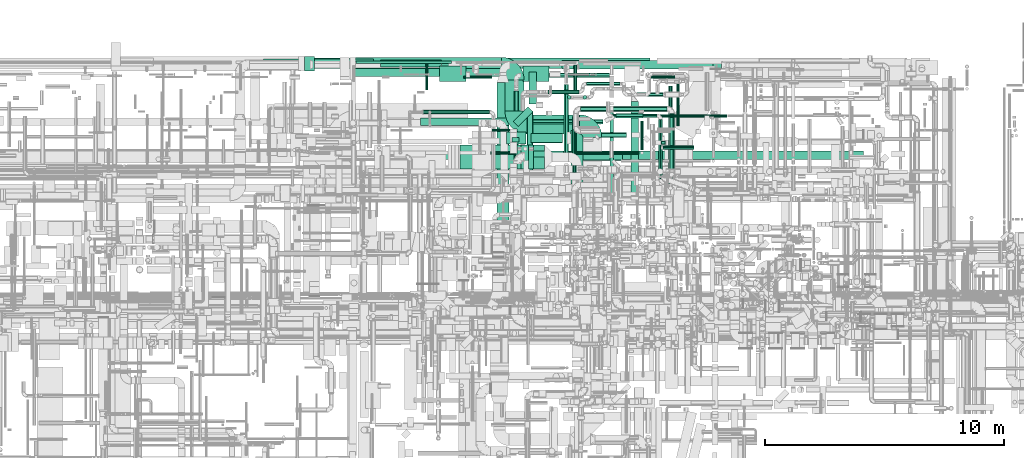
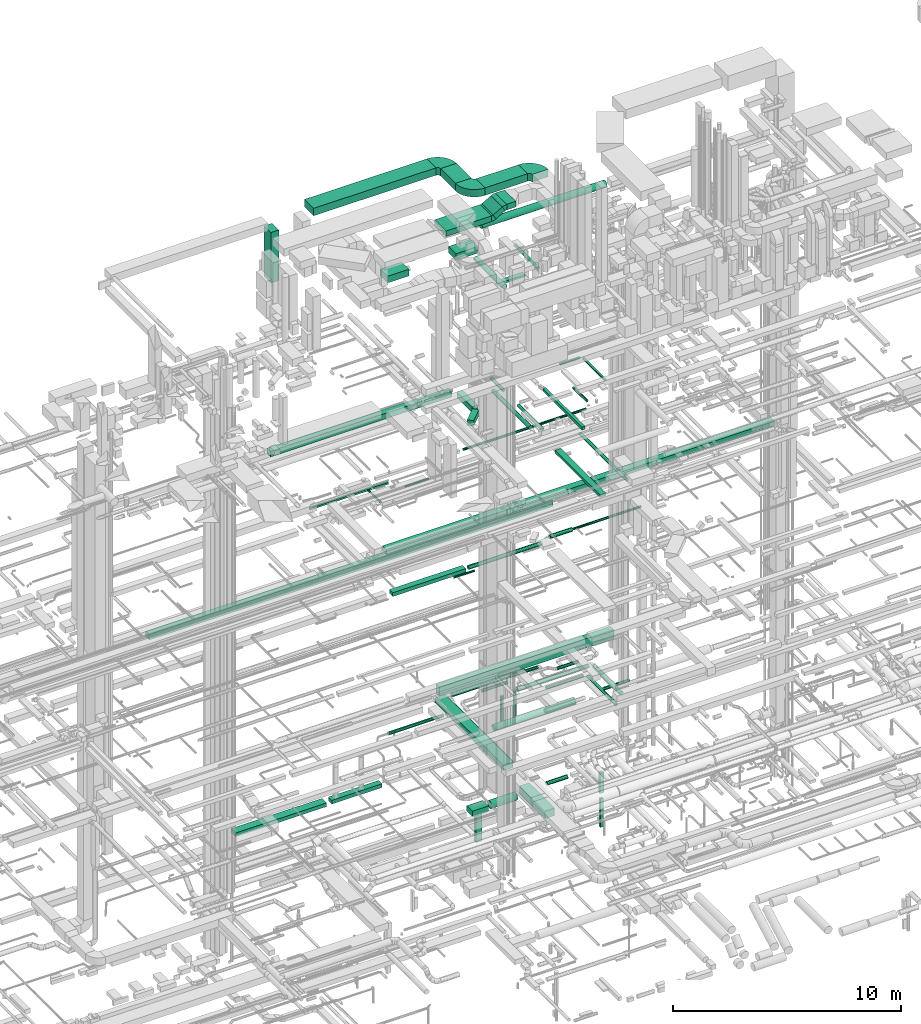
# One storey, part 74 of 337: 61 flow segments, 5 flow fittings.
"""IFC2X3 building model written with IfcOpenShell, lengths in millimetres."""

from ifc_helpers import new_model, entity, si_unit, converted_unit, derived_unit, direction, frame, frame_2d, origin, origin_2d_with_axis, place, context, subcontext, project, spatial, polyline, circle_curve, parameter, trimmed, segment, composite_curve, rectangle, circle, outline, extrude, source, transform, mapped, material, type_object, type_shapes, element, save


model = new_model("IFC2X3")

# Units and contexts
model_context = context("Model", 3, precision=0.01, world=origin(), true_north=direction((6.12303176911189e-17, 1.0)))
body_context = subcontext(model_context, "Body", "Model", "MODEL_VIEW")
ifc_project = project(units=[si_unit("LENGTHUNIT", "METRE", prefix="MILLI"), si_unit("AREAUNIT", "SQUARE_METRE"), si_unit("VOLUMEUNIT", "CUBIC_METRE"), converted_unit("PLANEANGLEUNIT", "DEGREE", entity("IfcRatioMeasure", 0.0174532925199433), si_unit("PLANEANGLEUNIT", "RADIAN"), dimensions=[0, 0, 0, 0, 0, 0, 0]), si_unit("MASSUNIT", "GRAM", prefix="KILO"), derived_unit("MASSDENSITYUNIT", [(si_unit("MASSUNIT", "GRAM", prefix="KILO"), 1), (si_unit("LENGTHUNIT", "METRE"), -3)]), derived_unit("MOMENTOFINERTIAUNIT", [(si_unit("LENGTHUNIT", "METRE"), 4)]), si_unit("TIMEUNIT", "SECOND"), si_unit("FREQUENCYUNIT", "HERTZ"), si_unit("THERMODYNAMICTEMPERATUREUNIT", "DEGREE_CELSIUS"), derived_unit("THERMALTRANSMITTANCEUNIT", [(si_unit("MASSUNIT", "GRAM", prefix="KILO"), 1), (si_unit("THERMODYNAMICTEMPERATUREUNIT", "KELVIN"), -1), (si_unit("TIMEUNIT", "SECOND"), -3)]), derived_unit("VOLUMETRICFLOWRATEUNIT", [(si_unit("LENGTHUNIT", "METRE"), 3), (si_unit("TIMEUNIT", "SECOND"), -1)]), derived_unit("MASSFLOWRATEUNIT", [(si_unit("MASSUNIT", "GRAM", prefix="KILO"), 1), (si_unit("TIMEUNIT", "SECOND"), -1)]), derived_unit("ROTATIONALFREQUENCYUNIT", [(si_unit("TIMEUNIT", "SECOND"), -1)]), si_unit("ELECTRICCURRENTUNIT", "AMPERE"), si_unit("ELECTRICVOLTAGEUNIT", "VOLT"), si_unit("POWERUNIT", "WATT"), si_unit("FORCEUNIT", "NEWTON", prefix="KILO"), si_unit("ILLUMINANCEUNIT", "LUX"), si_unit("LUMINOUSFLUXUNIT", "LUMEN"), si_unit("LUMINOUSINTENSITYUNIT", "CANDELA"), derived_unit("USERDEFINED", [(si_unit("MASSUNIT", "GRAM", prefix="KILO"), -1), (si_unit("LENGTHUNIT", "METRE"), -2), (si_unit("TIMEUNIT", "SECOND"), 3), (si_unit("LUMINOUSFLUXUNIT", "LUMEN"), 1)]), derived_unit("LINEARVELOCITYUNIT", [(si_unit("LENGTHUNIT", "METRE"), 1), (si_unit("TIMEUNIT", "SECOND"), -1)]), si_unit("PRESSUREUNIT", "PASCAL"), derived_unit("USERDEFINED", [(si_unit("LENGTHUNIT", "METRE"), -2), (si_unit("MASSUNIT", "GRAM", prefix="KILO"), 1), (si_unit("TIMEUNIT", "SECOND"), -2)]), derived_unit("LINEARFORCEUNIT", [(si_unit("MASSUNIT", "GRAM", prefix="KILO"), 1), (si_unit("LENGTHUNIT", "METRE"), 1), (si_unit("TIMEUNIT", "SECOND"), -2), (si_unit("LENGTHUNIT", "METRE"), -1)]), derived_unit("PLANARFORCEUNIT", [(si_unit("MASSUNIT", "GRAM", prefix="KILO"), 1), (si_unit("LENGTHUNIT", "METRE"), 1), (si_unit("TIMEUNIT", "SECOND"), -2), (si_unit("LENGTHUNIT", "METRE"), -2)])], contexts=[model_context])

# Site, building, storey
site_placement = place(None, origin())
site = spatial("IfcSite", under=ifc_project, at=site_placement, CompositionType="ELEMENT")
building_placement = place(site_placement, origin())
building = spatial("IfcBuilding", under=site, at=building_placement, CompositionType="ELEMENT")
storey_placement = place(building_placement, origin())
storey = spatial("IfcBuildingStorey", under=building, at=storey_placement, CompositionType="ELEMENT", Elevation=0.0)

# Flow segments
duct_segment_type_1 = type_object("IfcDuctSegmentType", PredefinedType="NOTDEFINED")
flow_segment_1_placement = place(storey_placement, frame((36314.51, 19663.8, -700.0)))
element("IfcFlowSegment", 1, at=flow_segment_1_placement, inside=storey, type_object=duct_segment_type_1, context=body_context, shape_type="SweptSolid", body=[
    extrude(rectangle(XDim=4599.07089300011, YDim=400.0, at=origin_2d_with_axis()), frame((2299.54, 200.0, 0.0)), (0.0, 0.0, 1.0), 200.0),
])
flow_segment_2_placement = place(storey_placement, frame((41213.58, 19713.8, -700.0)))
element("IfcFlowSegment", 2, at=flow_segment_2_placement, inside=storey, type_object=duct_segment_type_1, context=body_context, shape_type="SweptSolid", body=[
    extrude(rectangle(XDim=2541.39164700007, YDim=300.000000000001, at=origin_2d_with_axis()), frame((1270.7, 150.0, 0.0)), (0.0, 0.0, 1.0), 200.0),
])
flow_segment_3_placement = place(storey_placement, frame((49169.33, 14818.39, -1300.0)))
element("IfcFlowSegment", 3, at=flow_segment_3_placement, inside=storey, type_object=duct_segment_type_1, context=body_context, shape_type="SweptSolid", body=[
    extrude(rectangle(XDim=2239.99999999998, YDim=499.999999999999, at=origin_2d_with_axis()), frame((250.0, 1120.0, 0.0), z_axis=(0.0, 0.0, 1.0), x_axis=(0.0, 1.0, 0.0)), (0.0, 0.0, 1.0), 400.0),
])
flow_segment_4_placement = place(storey_placement, frame((52926.91, 16473.87, -2275.0)))
element("IfcFlowSegment", 4, at=flow_segment_4_placement, inside=storey, type_object=duct_segment_type_1, context=body_context, shape_type="SweptSolid", body=[
    extrude(rectangle(XDim=150.000000000001, YDim=199.999999999998, at=origin_2d_with_axis()), frame((100.0, 75.0, 0.0), z_axis=(0.0, 0.0, 1.0), x_axis=(0.0, 1.0, 0.0)), (0.0, 0.0, 1.0), 1079.99998577772),
])
flow_segment_5_placement = place(storey_placement, frame((52951.91, 16498.87, -4115.0)))
element("IfcFlowSegment", 5, at=flow_segment_5_placement, inside=storey, type_object=duct_segment_type_1, context=body_context, shape_type="SweptSolid", body=[
    extrude(rectangle(XDim=99.9999999999989, YDim=150.000000000001, at=origin_2d_with_axis()), frame((75.0, 50.0, 0.0), z_axis=(0.0, 0.0, 1.0), x_axis=(0.0, 1.0, 0.0)), (0.0, 0.0, 1.0), 1540.00000000006),
])
flow_segment_6_placement = place(storey_placement, frame((46476.19, 16499.25, -1275.0)))
element("IfcFlowSegment", 6, at=flow_segment_6_placement, inside=storey, type_object=duct_segment_type_1, context=body_context, shape_type="SweptSolid", body=[
    extrude(rectangle(XDim=816.497543824669, YDim=500.000000000001, at=origin_2d_with_axis()), frame((408.25, 250.0, 0.0), z_axis=(0.0, 0.0, 1.0), x_axis=(-1.0, 0.0, 0.0)), (0.0, 0.0, 1.0), 300.0),
])
flow_segment_7_placement = place(storey_placement, frame((46701.91, 16574.25, -2790.0)))
element("IfcFlowSegment", 7, at=flow_segment_7_placement, inside=storey, type_object=duct_segment_type_1, context=body_context, shape_type="SweptSolid", body=[
    extrude(rectangle(XDim=300.000000000001, YDim=200.0, at=origin_2d_with_axis()), frame((150.0, 100.0, 0.0)), (0.0, 0.0, 1.0), 1495.00000000003),
])
flow_segment_8_placement = place(storey_placement, frame((32013.84, 19801.06, 11250.0)))
element("IfcFlowSegment", 8, at=flow_segment_8_placement, inside=storey, type_object=duct_segment_type_1, context=body_context, shape_type="SweptSolid", body=[
    extrude(rectangle(XDim=20460.0, YDim=300.000000000001, at=origin_2d_with_axis()), frame((10230.0, 150.0, 0.0), z_axis=(0.0, 0.0, 1.0), x_axis=(-1.0, 0.0, 0.0)), (0.0, 0.0, 1.0), 300.000000000001),
])
flow_segment_9_placement = place(storey_placement, frame((42886.82, 17278.1, 11300.0)))
element("IfcFlowSegment", 9, at=flow_segment_9_placement, inside=storey, type_object=duct_segment_type_1, context=body_context, shape_type="SweptSolid", body=[
    extrude(rectangle(XDim=3700.48000586036, YDim=299.999999999999, at=origin_2d_with_axis()), frame((1850.24, 150.0, 0.0)), (0.0, 0.0, 1.0), 199.999999999998),
])
flow_segment_10_placement = place(storey_placement, frame((46625.84, 19646.24, 3200.0)))
element("IfcFlowSegment", 10, at=flow_segment_10_placement, inside=storey, type_object=duct_segment_type_1, context=body_context, shape_type="SweptSolid", body=[
    extrude(rectangle(XDim=8830.00000000004, YDim=300.000000000001, at=origin_2d_with_axis()), frame((4415.0, 150.0, 0.0), z_axis=(0.0, 0.0, 1.0), x_axis=(-1.0, 0.0, 0.0)), (0.0, 0.0, 1.0), 500.0),
])
flow_segment_11_placement = place(storey_placement, frame((38062.78, 19650.32, 19020.0)))
element("IfcFlowSegment", 11, at=flow_segment_11_placement, inside=storey, type_object=duct_segment_type_1, context=body_context, shape_type="SweptSolid", body=[
    extrude(rectangle(XDim=9206.25000000004, YDim=300.000000000001, at=origin_2d_with_axis()), frame((4603.13, 150.0, 0.0)), (0.0, 0.0, 1.0), 300.000000000001),
])
flow_segment_12_placement = place(storey_placement, frame((41748.68, 15850.0, 14825.0)))
element("IfcFlowSegment", 12, at=flow_segment_12_placement, inside=storey, type_object=duct_segment_type_1, context=body_context, shape_type="SweptSolid", body=[
    extrude(rectangle(XDim=19645.3394213711, YDim=350.000000000001, at=origin_2d_with_axis()), frame((9822.67, 175.0, 0.0)), (0.0, 0.0, 1.0), 249.999999999999),
])
flow_segment_13_placement = place(storey_placement, frame((50799.92, 14382.73, 19200.0)))
element("IfcFlowSegment", 13, at=flow_segment_13_placement, inside=storey, type_object=duct_segment_type_1, context=body_context, shape_type="SweptSolid", body=[
    extrude(rectangle(XDim=3427.07429120735, YDim=150.000000000001, at=origin_2d_with_axis()), frame((75.0, 1713.54, 0.0), z_axis=(0.0, 0.0, 1.0), x_axis=(0.0, -1.0, 0.0)), (0.0, 0.0, 1.0), 150.000000000001),
])
flow_segment_14_placement = place(storey_placement, frame((40192.01, 19863.88, 15300.0)))
element("IfcFlowSegment", 14, at=flow_segment_14_placement, inside=storey, type_object=duct_segment_type_1, context=body_context, shape_type="SweptSolid", body=[
    extrude(rectangle(XDim=3980.0, YDim=99.9999999999989, at=origin_2d_with_axis()), frame((1990.0, 50.0, 0.0)), (0.0, 0.0, 1.0), 99.9999999999989),
])
flow_segment_15_placement = place(storey_placement, frame((47419.03, 18167.72, 19020.0)))
element("IfcFlowSegment", 15, at=flow_segment_15_placement, inside=storey, type_object=duct_segment_type_1, context=body_context, shape_type="SweptSolid", body=[
    extrude(rectangle(XDim=1332.59991693868, YDim=300.000000000001, at=origin_2d_with_axis()), frame((150.0, 666.3, 0.0), z_axis=(0.0, 0.0, 1.0), x_axis=(0.0, -1.0, 0.0)), (0.0, 0.0, 1.0), 300.000000000001),
])
flow_segment_16_placement = place(storey_placement, frame((46750.83, 17225.26, 19020.0)))
element("IfcFlowSegment", 16, at=flow_segment_16_placement, inside=storey, type_object=duct_segment_type_1, context=body_context, shape_type="SweptSolid", body=[
    extrude(rectangle(XDim=882.842712474627, YDim=299.999999999999, at=origin_2d_with_axis()), frame((418.2, 418.2, 0.0), z_axis=(0.0, 0.0, 1.0), x_axis=(-0.707106781186576, -0.707106781186519, 0.0)), (0.0, 0.0, 1.0), 300.000000000001),
])
flow_segment_17_placement = place(storey_placement, frame((47583.77, 15953.71, 27150.0)))
element("IfcFlowSegment", 17, at=flow_segment_17_placement, inside=storey, type_object=duct_segment_type_1, context=body_context, shape_type="SweptSolid", body=[
    extrude(rectangle(XDim=1265.00000000001, YDim=249.999999999999, at=origin_2d_with_axis()), frame((632.5, 125.0, 0.0)), (0.0, 0.0, 1.0), 100.000000000003),
])
flow_segment_18_placement = place(storey_placement, frame((38040.11, 19554.6, 28396.21)))
element("IfcFlowSegment", 18, at=flow_segment_18_placement, inside=storey, type_object=duct_segment_type_1, context=body_context, shape_type="SweptSolid", body=[
    extrude(rectangle(XDim=600.000000000002, YDim=400.0, at=origin_2d_with_axis()), frame((200.0, 300.0, 0.0), z_axis=(0.0, 0.0, 1.0), x_axis=(0.0, 1.0, 0.0)), (0.0, 0.0, 1.0), 2703.78939319796),
])
flow_segment_19_placement = place(storey_placement, frame((40063.7, 19323.62, 31430.26)))
element("IfcFlowSegment", 19, at=flow_segment_19_placement, inside=storey, type_object=duct_segment_type_1, context=body_context, shape_type="SweptSolid", body=[
    extrude(rectangle(XDim=6196.33097530317, YDim=800.0, at=origin_2d_with_axis()), frame((3098.17, 400.0, 0.0)), (0.0, 0.0, 1.0), 400.000000000004),
])
flow_segment_20_placement = place(storey_placement, frame((46410.03, 17872.3, 31430.26)))
element("IfcFlowSegment", 20, at=flow_segment_20_placement, inside=storey, type_object=duct_segment_type_1, context=body_context, shape_type="SweptSolid", body=[
    extrude(rectangle(XDim=1301.32265135034, YDim=800.0, at=origin_2d_with_axis()), frame((400.0, 650.66, 0.0), z_axis=(0.0, 0.0, 1.0), x_axis=(0.0, -1.0, 0.0)), (0.0, 0.0, 1.0), 400.000000000004),
])
flow_segment_21_placement = place(storey_placement, frame((47360.03, 16922.3, 31430.26)))
element("IfcFlowSegment", 21, at=flow_segment_21_placement, inside=storey, type_object=duct_segment_type_1, context=body_context, shape_type="SweptSolid", body=[
    extrude(rectangle(XDim=2155.36247529735, YDim=800.0, at=origin_2d_with_axis()), frame((1077.68, 400.0, 0.0)), (0.0, 0.0, 1.0), 400.000000000004),
])
flow_segment_22_placement = place(storey_placement, frame((44538.7, 15454.64, 31100.0)))
element("IfcFlowSegment", 22, at=flow_segment_22_placement, inside=storey, type_object=duct_segment_type_1, context=body_context, shape_type="SweptSolid", body=[
    extrude(rectangle(XDim=2306.34803549971, YDim=1000.0, at=origin_2d_with_axis()), frame((1153.17, 500.0, 0.0)), (0.0, 0.0, 1.0), 300.000000000001),
])
flow_segment_23_placement = place(storey_placement, frame((47612.03, 15454.64, 31450.0)))
element("IfcFlowSegment", 23, at=flow_segment_23_placement, inside=storey, type_object=duct_segment_type_1, context=body_context, shape_type="SweptSolid", body=[
    extrude(rectangle(XDim=460.000000000155, YDim=1000.0, at=origin_2d_with_axis()), frame((230.0, 500.0, 0.0), z_axis=(0.0, 0.0, 1.0), x_axis=(-1.0, 0.0, 0.0)), (0.0, 0.0, 1.0), 300.000000000001),
])
flow_segment_24_placement = place(storey_placement, frame((46920.05, 15454.64, 31160.29)))
element("IfcFlowSegment", 24, at=flow_segment_24_placement, inside=storey, type_object=duct_segment_type_1, context=body_context, shape_type="SweptSolid", body=[
    extrude(rectangle(XDim=300.000000000005, YDim=539.230505796841, at=frame_2d((0.0, 0.0), x_axis=(0.0, 1.0))), frame((308.49, 0.0, 264.71), z_axis=(0.0, 1.0, 0.0), x_axis=(0.866025410712811, 0.0, 0.499999987999707)), (0.0, 0.0, 1.0), 999.999999999997),
])
flow_segment_25_placement = place(storey_placement, frame((46075.84, 13096.24, 3400.0)))
element("IfcFlowSegment", 25, at=flow_segment_25_placement, inside=storey, type_object=duct_segment_type_1, context=body_context, shape_type="SweptSolid", body=[
    extrude(rectangle(XDim=5974.82718057202, YDim=499.999999999999, at=origin_2d_with_axis()), frame((250.0, 2987.41, 0.0), z_axis=(0.0, 0.0, 1.0), x_axis=(0.0, -1.0, 0.0)), (0.0, 0.0, 1.0), 300.0),
])
for number, where in (
    (26, (47158.2, 19108.98, 26700.0)),
    (27, (43683.2, 19108.98, 26700.0)),
):
    element("IfcFlowSegment", number, at=place(storey_placement, frame(where)), inside=storey, type_object=duct_segment_type_1, context=body_context, shape_type="SweptSolid", body=[
        extrude(rectangle(XDim=1100.0, YDim=650.0, at=origin_2d_with_axis()), frame((550.0, 325.0, 0.0)), (0.0, 0.0, 1.0), 349.999999999998),
    ])
flow_segment_26_placement = place(storey_placement, frame((51683.97, 14338.91, 15300.0)))
element("IfcFlowSegment", 28, at=flow_segment_26_placement, inside=storey, type_object=duct_segment_type_1, context=body_context, shape_type="SweptSolid", body=[
    extrude(rectangle(XDim=3941.04074498559, YDim=300.000000000001, at=origin_2d_with_axis()), frame((150.0, 1970.52, 0.0), z_axis=(0.0, 0.0, 1.0), x_axis=(0.0, -1.0, 0.0)), (0.0, 0.0, 1.0), 150.000000000001),
])
duct_segment_type_2 = type_object("IfcDuctSegmentType", PredefinedType="NOTDEFINED")
flow_segment_27_placement = place(storey_placement, frame((50435.1, 16772.29, -1201.6)))
element("IfcFlowSegment", 29, at=flow_segment_27_placement, inside=storey, type_object=duct_segment_type_2, context=body_context, shape_type="SweptSolid", body=[
    extrude(circle(Radius=100.0, at=origin_2d_with_axis()), frame((0.0, 101.6, 101.6), z_axis=(1.0, 0.0, 0.0), x_axis=(0.0, -1.0, 0.0)), (0.0, 0.0, 1.0), 1055.9862289823),
])
flow_segment_28_placement = place(storey_placement, frame((47492.69, 16547.66, -1326.6)))
element("IfcFlowSegment", 30, at=flow_segment_28_placement, inside=storey, type_object=duct_segment_type_2, context=body_context, shape_type="SweptSolid", body=[
    extrude(circle(Radius=200.0, at=origin_2d_with_axis()), frame((0.0, 201.6, 201.6), z_axis=(1.0, 0.0, 0.0), x_axis=(0.0, 1.0, 0.0)), (0.0, 0.0, 1.0), 1313.2040618354),
])
flow_segment_29_placement = place(storey_placement, frame((51060.03, 17576.51, 11298.4)))
element("IfcFlowSegment", 31, at=flow_segment_29_placement, inside=storey, type_object=duct_segment_type_2, context=body_context, shape_type="SweptSolid", body=[
    extrude(circle(Radius=100.0, at=origin_2d_with_axis()), frame((0.0, 101.6, 101.6), z_axis=(1.0, 0.0, 0.0), x_axis=(0.0, -1.0, 0.0)), (0.0, 0.0, 1.0), 1127.26454431082),
])
flow_segment_30_placement = place(storey_placement, frame((52262.3, 17614.01, 11335.9)))
element("IfcFlowSegment", 32, at=flow_segment_30_placement, inside=storey, type_object=duct_segment_type_2, context=body_context, shape_type="SweptSolid", body=[
    extrude(circle(Radius=62.5, at=origin_2d_with_axis()), frame((0.0, 64.1, 64.1), z_axis=(1.0, 0.0, 0.0), x_axis=(0.0, -1.0, 0.0)), (0.0, 0.0, 1.0), 3424.99999999999),
])
flow_segment_31_placement = place(storey_placement, frame((45868.74, 17027.64, 11348.4)))
element("IfcFlowSegment", 33, at=flow_segment_31_placement, inside=storey, type_object=duct_segment_type_2, context=body_context, shape_type="SweptSolid", body=[
    extrude(circle(Radius=50.0, at=origin_2d_with_axis()), frame((0.0, 51.6, 51.6), z_axis=(1.0, 0.0, 0.0), x_axis=(0.0, -1.0, 0.0)), (0.0, 0.0, 1.0), 1040.00000000003),
])
flow_segment_32_placement = place(storey_placement, frame((47237.72, 15818.32, 3390.9)))
element("IfcFlowSegment", 34, at=flow_segment_32_placement, inside=storey, type_object=duct_segment_type_2, context=body_context, shape_type="SweptSolid", body=[
    extrude(circle(Radius=157.5, at=origin_2d_with_axis()), frame((0.0, 159.1, 159.1), z_axis=(1.0, 0.0, 0.0), x_axis=(0.0, 1.0, 0.0)), (0.0, 0.0, 1.0), 4095.00022628647),
])
flow_segment_33_placement = place(storey_placement, frame((46787.3, 17326.51, 11298.4)))
element("IfcFlowSegment", 35, at=flow_segment_33_placement, inside=storey, type_object=duct_segment_type_2, context=body_context, shape_type="SweptSolid", body=[
    extrude(circle(Radius=100.0, at=origin_2d_with_axis()), frame((0.0, 101.6, 101.6), z_axis=(1.0, 0.0, 0.0), x_axis=(0.0, -1.0, 0.0)), (0.0, 0.0, 1.0), 3718.27648312894),
])
flow_segment_34_placement = place(storey_placement, frame((42991.64, 17750.38, 3518.4)))
element("IfcFlowSegment", 36, at=flow_segment_34_placement, inside=storey, type_object=duct_segment_type_2, context=body_context, shape_type="SweptSolid", body=[
    extrude(circle(Radius=80.0, at=origin_2d_with_axis()), frame((0.0, 81.6, 81.6), z_axis=(1.0, 0.0, 0.0), x_axis=(0.0, 1.0, 0.0)), (0.0, 0.0, 1.0), 2775.00000000001),
])
flow_segment_35_placement = place(storey_placement, frame((53578.72, 17247.82, 19085.9)))
element("IfcFlowSegment", 37, at=flow_segment_35_placement, inside=storey, type_object=duct_segment_type_2, context=body_context, shape_type="SweptSolid", body=[
    extrude(circle(Radius=62.5, at=origin_2d_with_axis()), frame((64.1, 0.0, 64.1), z_axis=(0.0, 1.0, 0.0), x_axis=(1.0, 0.0, 0.0)), (0.0, 0.0, 1.0), 1927.5),
])
flow_segment_36_placement = place(storey_placement, frame((52521.56, 19236.23, 19085.9)))
element("IfcFlowSegment", 38, at=flow_segment_36_placement, inside=storey, type_object=duct_segment_type_2, context=body_context, shape_type="SweptSolid", body=[
    extrude(circle(Radius=62.5, at=origin_2d_with_axis()), frame((0.0, 64.1, 64.1), z_axis=(1.0, 0.0, 0.0), x_axis=(0.0, 1.0, 0.0)), (0.0, 0.0, 1.0), 996.249999999994),
])
flow_segment_37_placement = place(storey_placement, frame((52075.86, 16256.51, 19085.9)))
element("IfcFlowSegment", 39, at=flow_segment_37_placement, inside=storey, type_object=duct_segment_type_2, context=body_context, shape_type="SweptSolid", body=[
    extrude(circle(Radius=62.5, at=origin_2d_with_axis()), frame((64.1, 0.0, 64.1), z_axis=(0.0, 1.0, 0.0), x_axis=(1.0, 0.0, 0.0)), (0.0, 0.0, 1.0), 1195.00000000004),
])
flow_segment_38_placement = place(storey_placement, frame((49241.24, 15318.63, 19143.4)))
element("IfcFlowSegment", 40, at=flow_segment_38_placement, inside=storey, type_object=duct_segment_type_2, context=body_context, shape_type="SweptSolid", body=[
    extrude(circle(Radius=80.0, at=origin_2d_with_axis()), frame((81.6, 0.0, 81.6), z_axis=(0.0, 1.0, 0.0), x_axis=(-1.0, 0.0, 0.0)), (0.0, 0.0, 1.0), 2070.43368990205),
])
flow_segment_39_placement = place(storey_placement, frame((49268.32, 18743.85, 19110.32)))
element("IfcFlowSegment", 41, at=flow_segment_39_placement, inside=storey, type_object=duct_segment_type_2, context=body_context, shape_type="SweptSolid", body=[
    extrude(circle(Radius=80.0, at=origin_2d_with_axis()), frame((81.6, 0.0, 81.6), z_axis=(0.0, 1.0, 0.0), x_axis=(-1.0, 0.0, 0.0)), (0.0, 0.0, 1.0), 1066.25),
])
flow_segment_40_placement = place(storey_placement, frame((53248.32, 14818.91, 15308.4)))
element("IfcFlowSegment", 42, at=flow_segment_40_placement, inside=storey, type_object=duct_segment_type_2, context=body_context, shape_type="SweptSolid", body=[
    extrude(circle(Radius=80.0, at=origin_2d_with_axis()), frame((81.6, 0.0, 81.6), z_axis=(0.0, 1.0, 0.0), x_axis=(-1.0, 0.0, 0.0)), (0.0, 0.0, 1.0), 4100.00000000001),
])
flow_segment_41_placement = place(storey_placement, frame((48868.15, 15738.53, 19053.4)))
element("IfcFlowSegment", 43, at=flow_segment_41_placement, inside=storey, type_object=duct_segment_type_2, context=body_context, shape_type="SweptSolid", body=[
    extrude(circle(Radius=100.0, at=origin_2d_with_axis()), frame((101.6, 0.0, 101.6), z_axis=(0.0, 1.0, 0.0), x_axis=(-1.0, 0.0, 0.0)), (0.0, 0.0, 1.0), 3251.98424818398),
])
flow_segment_42_placement = place(storey_placement, frame((45798.08, 16067.41, 18785.9)))
element("IfcFlowSegment", 44, at=flow_segment_42_placement, inside=storey, type_object=duct_segment_type_2, context=body_context, shape_type="SweptSolid", body=[
    extrude(circle(Radius=62.5, at=origin_2d_with_axis()), frame((0.0, 64.1, 64.1), z_axis=(1.0, 0.0, 0.0), x_axis=(0.0, 1.0, 0.0)), (0.0, 0.0, 1.0), 6216.87501011495),
])
flow_segment_43_placement = place(storey_placement, frame((43085.27, 18763.88, 15298.4)))
element("IfcFlowSegment", 45, at=flow_segment_43_placement, inside=storey, type_object=duct_segment_type_2, context=body_context, shape_type="SweptSolid", body=[
    extrude(circle(Radius=50.0, at=origin_2d_with_axis()), frame((51.6, 0.0, 51.6), z_axis=(0.0, 1.0, 0.0), x_axis=(-1.0, 0.0, 0.0)), (0.0, 0.0, 1.0), 1080.0),
])
flow_segment_44_placement = place(storey_placement, frame((44673.4, 19241.69, 15298.4)))
element("IfcFlowSegment", 46, at=flow_segment_44_placement, inside=storey, type_object=duct_segment_type_2, context=body_context, shape_type="SweptSolid", body=[
    extrude(circle(Radius=50.0, at=origin_2d_with_axis()), frame((0.0, 51.6, 51.6), z_axis=(1.0, 0.0, 0.0), x_axis=(0.0, -1.0, 0.0)), (0.0, 0.0, 1.0), 1200.0),
])
flow_segment_45_placement = place(storey_placement, frame((49220.97, 15621.83, 27568.4)))
element("IfcFlowSegment", 47, at=flow_segment_45_placement, inside=storey, type_object=duct_segment_type_2, context=body_context, shape_type="SweptSolid", body=[
    extrude(circle(Radius=80.0, at=origin_2d_with_axis()), frame((81.6, 0.0, 81.6), z_axis=(0.0, 1.0, 0.0), x_axis=(1.0, 0.0, 0.0)), (0.0, 0.0, 1.0), 2018.74999999999),
])
flow_segment_46_placement = place(storey_placement, frame((47329.83, 15363.09, 27323.4)))
element("IfcFlowSegment", 48, at=flow_segment_46_placement, inside=storey, type_object=duct_segment_type_2, context=body_context, shape_type="SweptSolid", body=[
    extrude(circle(Radius=125.0, at=origin_2d_with_axis()), frame((126.6, 0.0, 126.6), z_axis=(0.0, 1.0, 0.0), x_axis=(1.0, 0.0, 0.0)), (0.0, 0.0, 1.0), 2512.26215624299),
])
flow_segment_47_placement = place(storey_placement, frame((48785.11, 19627.39, 27420.9)))
element("IfcFlowSegment", 49, at=flow_segment_47_placement, inside=storey, type_object=duct_segment_type_2, context=body_context, shape_type="SweptSolid", body=[
    extrude(circle(Radius=177.5, at=origin_2d_with_axis()), frame((0.0, 179.1, 179.1), z_axis=(1.0, 0.0, 0.0), x_axis=(0.0, -1.0, 0.0)), (0.0, 0.0, 1.0), 6316.53048256007),
])
flow_segment_48_placement = place(storey_placement, frame((48199.61, 18597.52, 3468.4)))
element("IfcFlowSegment", 50, at=flow_segment_48_placement, inside=storey, type_object=duct_segment_type_2, context=body_context, shape_type="SweptSolid", body=[
    extrude(circle(Radius=80.0, at=origin_2d_with_axis()), frame((0.0, 81.6, 81.6), z_axis=(1.0, 0.0, 0.0), x_axis=(0.0, -1.0, 0.0)), (0.0, 0.0, 1.0), 1303.72583002035),
])
flow_segment_49_placement = place(storey_placement, frame((49823.34, 18937.52, 3468.4)))
element("IfcFlowSegment", 51, at=flow_segment_49_placement, inside=storey, type_object=duct_segment_type_2, context=body_context, shape_type="SweptSolid", body=[
    extrude(circle(Radius=80.0, at=origin_2d_with_axis()), frame((0.0, 81.6, 81.6), z_axis=(1.0, 0.0, 0.0), x_axis=(0.0, -1.0, 0.0)), (0.0, 0.0, 1.0), 1402.50000000002),
])
flow_segment_50_placement = place(storey_placement, frame((51934.61, 18482.52, 3418.4)))
element("IfcFlowSegment", 52, at=flow_segment_50_placement, inside=storey, type_object=duct_segment_type_2, context=body_context, shape_type="SweptSolid", body=[
    extrude(circle(Radius=80.0, at=origin_2d_with_axis()), frame((0.0, 81.6, 81.6), z_axis=(1.0, 0.0, 0.0), x_axis=(0.0, 1.0, 0.0)), (0.0, 0.0, 1.0), 1088.72583002029),
])
flow_segment_51_placement = place(storey_placement, frame((49011.32, 18367.93, 1500.0)))
element("IfcFlowSegment", 53, at=flow_segment_51_placement, inside=storey, type_object=duct_segment_type_2, context=body_context, shape_type="SweptSolid", body=[
    extrude(circle(Radius=80.0, at=origin_2d_with_axis()), frame((81.6, 81.6, 0.0), z_axis=(0.0, 0.0, 1.0), x_axis=(0.0, -1.0, 0.0)), (0.0, 0.0, 1.0), 1610.00000000001),
])
flow_segment_52_placement = place(storey_placement, frame((49667.97, 18367.93, 1500.0)))
element("IfcFlowSegment", 54, at=flow_segment_52_placement, inside=storey, type_object=duct_segment_type_2, context=body_context, shape_type="SweptSolid", body=[
    extrude(circle(Radius=80.0, at=origin_2d_with_axis()), frame((81.6, 81.6, 0.0), z_axis=(0.0, 0.0, 1.0), x_axis=(0.0, -1.0, 0.0)), (0.0, 0.0, 1.0), 1669.99999999991),
])
flow_segment_53_placement = place(storey_placement, frame((46775.59, 13741.07, 3048.4)))
element("IfcFlowSegment", 55, at=flow_segment_53_placement, inside=storey, type_object=duct_segment_type_2, context=body_context, shape_type="SweptSolid", body=[
    extrude(circle(Radius=100.0, at=origin_2d_with_axis()), frame((101.6, 0.0, 101.6), z_axis=(0.0, 1.0, 0.0), x_axis=(-1.0, 0.0, 0.0)), (0.0, 0.0, 1.0), 4974.64235462484),
])
flow_segment_54_placement = place(storey_placement, frame((47077.19, 19269.47, 3198.4)))
element("IfcFlowSegment", 56, at=flow_segment_54_placement, inside=storey, type_object=duct_segment_type_2, context=body_context, shape_type="SweptSolid", body=[
    extrude(circle(Radius=100.0, at=origin_2d_with_axis()), frame((0.0, 101.6, 101.6), z_axis=(1.0, 0.0, 0.0), x_axis=(0.0, -1.0, 0.0)), (0.0, 0.0, 1.0), 3700.00000000002),
])
flow_segment_55_placement = place(storey_placement, frame((52835.15, 15038.74, 3298.4)))
element("IfcFlowSegment", 57, at=flow_segment_55_placement, inside=storey, type_object=duct_segment_type_2, context=body_context, shape_type="SweptSolid", body=[
    extrude(circle(Radius=80.0, at=origin_2d_with_axis()), frame((81.6, 0.0, 81.6), z_axis=(0.0, 1.0, 0.0), x_axis=(1.0, 0.0, 0.0)), (0.0, 0.0, 1.0), 2480.00000000001),
])
flow_segment_56_placement = place(storey_placement, frame((50876.74, 17597.14, 3298.4)))
element("IfcFlowSegment", 58, at=flow_segment_56_placement, inside=storey, type_object=duct_segment_type_2, context=body_context, shape_type="SweptSolid", body=[
    extrude(circle(Radius=80.0, at=origin_2d_with_axis()), frame((0.0, 81.6, 81.6), z_axis=(1.0, 0.0, 0.0), x_axis=(0.0, 1.0, 0.0)), (0.0, 0.0, 1.0), 1880.00000000002),
])
flow_segment_57_placement = place(storey_placement, frame((53016.74, 16266.44, 3298.4)))
element("IfcFlowSegment", 59, at=flow_segment_57_placement, inside=storey, type_object=duct_segment_type_2, context=body_context, shape_type="SweptSolid", body=[
    extrude(circle(Radius=80.0, at=origin_2d_with_axis()), frame((0.0, 81.6, 81.6), z_axis=(1.0, 0.0, 0.0), x_axis=(0.0, -1.0, 0.0)), (0.0, 0.0, 1.0), 1299.99999999998),
])
duct_segment_type_3 = type_object("IfcDuctSegmentType", PredefinedType="NOTDEFINED")
flow_segment_58_placement = place(storey_placement, frame((53286.67, 15415.07, 3478.4)))
element("IfcFlowSegment", 60, at=flow_segment_58_placement, inside=storey, type_object=duct_segment_type_3, context=body_context, shape_type="SweptSolid", body=[
    extrude(circle(Radius=100.0, at=origin_2d_with_axis()), frame((101.6, 0.0, 101.6), z_axis=(0.0, 1.0, 0.0), x_axis=(-1.0, 0.0, 0.0)), (0.0, 0.0, 1.0), 2350.00010685499),
])
flow_segment_59_placement = place(storey_placement, frame((49573.27, 17863.48, 3478.4)))
element("IfcFlowSegment", 61, at=flow_segment_59_placement, inside=storey, type_object=duct_segment_type_3, context=body_context, shape_type="SweptSolid", body=[
    extrude(circle(Radius=100.0, at=origin_2d_with_axis()), frame((0.0, 101.6, 101.6), z_axis=(1.0, 0.0, 0.0), x_axis=(0.0, 1.0, 0.0)), (0.0, 0.0, 1.0), 3615.00000000002),
])

# Flow fittings
ifc_material = material()
duct_fitting_type_1 = type_object("IfcDuctFittingType", PredefinedType="NOTDEFINED", material=ifc_material)
shared_shape_1 = source(origin(), body_context, "Body", "SweptSolid", [
    extrude(outline(composite_curve([segment(polyline([(-675.0, -275.0), (125.0, -275.0)]), True, "CONTINUOUS"), segment(trimmed(circle_curve(frame_2d((275.0, -275.0), x_axis=(0.0, 1.0)), 150.0), [parameter(0.0)], [parameter(90.0000000000001)], True, "PARAMETER"), False, "CONTINUOUS"), segment(polyline([(275.0, -125.0), (275.0, 675.0)]), True, "CONTINUOUS"), segment(trimmed(circle_curve(frame_2d((275.0, -275.0), x_axis=(0.0, 1.0)), 950.0), [parameter(0.0)], [parameter(90.0000000000001)], True, "PARAMETER"), True, "CONTINUOUS")], self_intersect=False)), frame((-275.0, 275.0, -200.0), z_axis=(0.0, 0.0, 1.0), x_axis=(-1.0, 0.0, 0.0)), (0.0, 0.0, 1.0), 400.0),
])
type_shapes(duct_fitting_type_1, [shared_shape_1])
for number, where, z_axis, x_axis in (
    (62, (46810.03, 19723.62, 31630.26), (0.0, 0.0, 1.0), (0.0, 1.0, 0.0)),
    (63, (46810.03, 17322.3, 31630.26), (0.0, 0.0, 1.0), (0.0, -1.0, 0.0)),
    (64, (50065.39, 17322.3, 31630.26), (0.0, 0.0, 1.0), (0.0, 1.0, 0.0)),
):
    element("IfcFlowFitting", number, at=place(storey_placement, frame(where, z_axis=z_axis, x_axis=x_axis)), inside=storey, type_object=duct_fitting_type_1, material=ifc_material, context=body_context, shape_type="MappedRepresentation", body=[
        mapped(shared_shape_1, transform((0.0, 0.0, 0.0), scale=1.0)),
    ])
duct_fitting_type_2 = type_object("IfcDuctFittingType", PredefinedType="NOTDEFINED", material=ifc_material)
shared_shape_2 = source(origin(), body_context, "Body", "SweptSolid", [
    extrude(outline(composite_curve([segment(polyline([(-170.1, -75.0), (129.9, -75.0)]), True, "CONTINUOUS"), segment(trimmed(circle_curve(frame_2d((279.9, -75.0), x_axis=(-0.866025410712655, 0.499999987999976)), 150.0), [parameter(0.0)], [parameter(29.9999992060848)], True, "PARAMETER"), False, "CONTINUOUS"), segment(polyline([(150.0, 0.0), (-109.81, 150.0)]), True, "CONTINUOUS"), segment(trimmed(circle_curve(frame_2d((279.9, -75.0), x_axis=(-0.866025410712655, 0.499999987999976)), 450.0), [parameter(0.0)], [parameter(29.9999992060848)], True, "PARAMETER"), True, "CONTINUOUS")], self_intersect=False)), frame((-5.38, 20.1, -500.0), z_axis=(0.0, 0.0, 1.0), x_axis=(-0.499999987999976, 0.866025410712655, 0.0)), (0.0, 0.0, 1.0), 1000.0),
])
type_shapes(duct_fitting_type_2, [shared_shape_2])
for number, where, z_axis, x_axis in (
    (65, (46925.43, 15954.64, 31250.0), (0.0, 1.0, 0.0), (-0.866025410712807, 0.0, -0.499999987999713)),
    (66, (47531.65, 15954.64, 31600.0), (0.0, 1.0, 0.0), (0.866025410712807, 0.0, 0.499999987999713)),
):
    element("IfcFlowFitting", number, at=place(storey_placement, frame(where, z_axis=z_axis, x_axis=x_axis)), inside=storey, type_object=duct_fitting_type_2, material=ifc_material, context=body_context, shape_type="MappedRepresentation", body=[
        mapped(shared_shape_2, transform((0.0, 0.0, 0.0), scale=1.0)),
    ])

save(model, "model.ifc")
